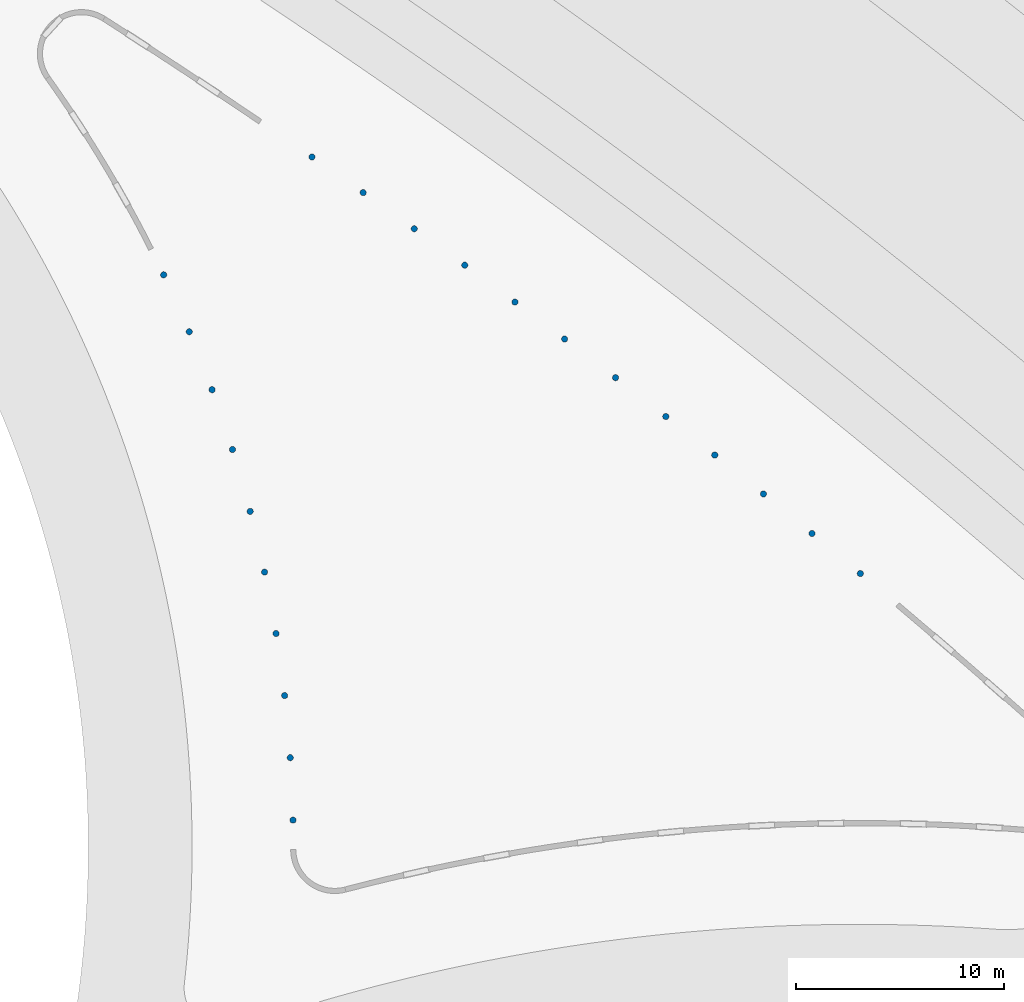
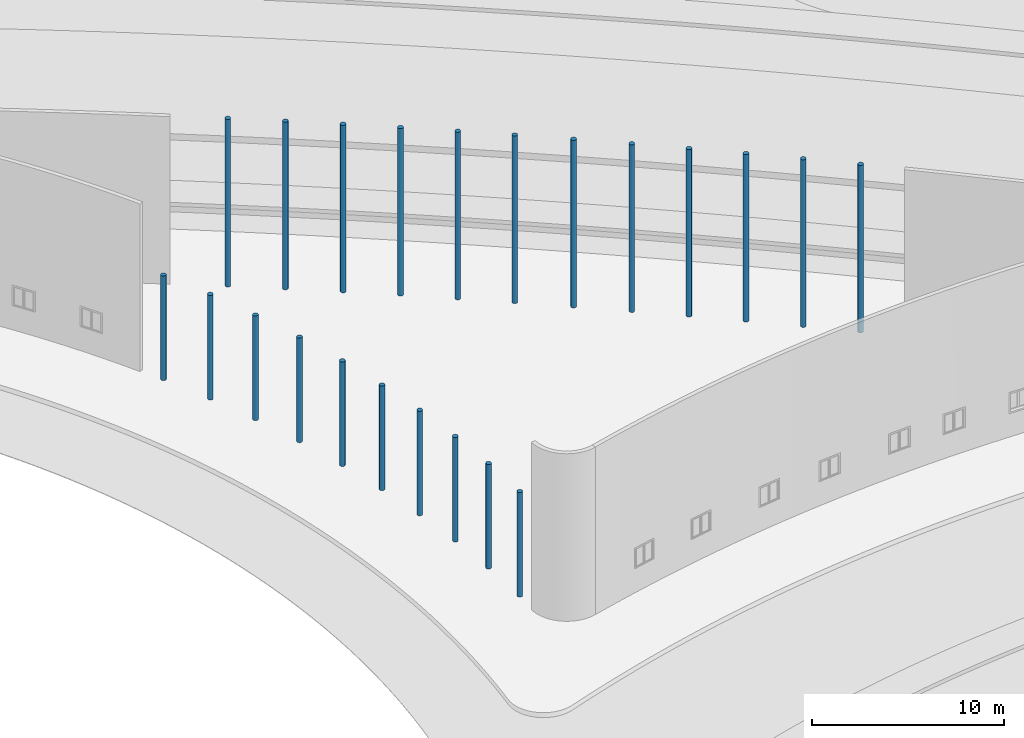
# One storey, part 5 of 39: 22 columns.
"""IFC2X3 building model written with IfcOpenShell, lengths in millimetres."""

from ifc_helpers import new_model, entity, si_unit, converted_unit, derived_unit, direction, frame, frame_2d, origin, place, context, subcontext, project, spatial, circle, extrude, source, transform, mapped, material, type_object, type_shapes, element, save


model = new_model("IFC2X3")

# Units and contexts
model_context = context("Model", 3, precision=1e-06, world=origin(), true_north=direction((2.0, 6.12303176911189e-17, 1.0)))
context_of_model = context(None, 3, precision=1e-06, world=origin(), true_north=direction((2.0, 6.12303176911189e-17, 1.0)))
body_context = subcontext(model_context, "Body", "Model", "MODEL_VIEW")
ifc_project = project(units=[si_unit("LENGTHUNIT", "METRE", prefix="MILLI"), si_unit("AREAUNIT", "SQUARE_METRE", prefix="MILLI"), si_unit("VOLUMEUNIT", "CUBIC_METRE", prefix="MILLI"), converted_unit("PLANEANGLEUNIT", "DEGREE", entity("IfcRatioMeasure", 0.0174532925199433), si_unit("PLANEANGLEUNIT", "RADIAN"), dimensions=[0, 0, 0, 0, 0, 0, 0]), si_unit("MASSUNIT", "GRAM", prefix="KILO"), si_unit("TIMEUNIT", "SECOND"), si_unit("THERMODYNAMICTEMPERATUREUNIT", "KELVIN"), derived_unit("THERMALTRANSMITTANCEUNIT", [(si_unit("MASSUNIT", "GRAM", prefix="KILO"), 1), (si_unit("THERMODYNAMICTEMPERATUREUNIT", "KELVIN"), -1), (si_unit("TIMEUNIT", "SECOND"), -3)]), derived_unit("VOLUMETRICFLOWRATEUNIT", [(si_unit("LENGTHUNIT", "METRE"), 3), (si_unit("TIMEUNIT", "SECOND"), -1)])], contexts=[model_context, context_of_model])

# Site, building, storey
site_placement = place(None, origin())
site = spatial("IfcSite", under=ifc_project, at=site_placement, CompositionType="ELEMENT")
building_placement = place(site_placement, origin())
building = spatial("IfcBuilding", under=site, at=building_placement, CompositionType="ELEMENT")
storey_placement = place(building_placement, frame((0.0, 0.0, 4000.0)))
storey = spatial("IfcBuildingStorey", under=building, at=storey_placement, Name="Level 2", CompositionType="ELEMENT", Elevation=4000.0)

# Columns
ifc_material = material(Name="Concrete - Cast-in-Place Concrete")
column_type_1 = type_object("IfcColumnType", Name="300mm", PredefinedType="COLUMN", material=ifc_material)
shared_shape_1 = source(origin(), body_context, "Body", "SweptSolid", [
    extrude(circle(Radius=149.999999999996, at=frame_2d((346754.447206508, 619569.745240384), x_axis=(1.0, 0.0))), origin(), (0.0, 0.0, 1.0), 10638.0),
])
type_shapes(column_type_1, [shared_shape_1])
column_1_placement = place(storey_placement, frame((0.0, 0.0, 362.0)))
element("IfcColumn", 1, at=column_1_placement, inside=storey, type_object=column_type_1, material=ifc_material, Name="M_Concrete-Round-Column:300mm", ObjectType="300mm", context=body_context, shape_type="MappedRepresentation", body=[
    mapped(shared_shape_1, transform((0.0, 0.0, 0.0), scale=1.0)),
])
column_type_2 = type_object("IfcColumnType", Name="300mm", PredefinedType="COLUMN", material=ifc_material)
shared_shape_2 = source(origin(), body_context, "Body", "SweptSolid", [
    extrude(circle(Radius=149.999999999996, at=frame_2d((349146.48282445, 617790.402335586), x_axis=(1.0, 0.0))), origin(), (0.0, 0.0, 1.0), 10638.0),
])
type_shapes(column_type_2, [shared_shape_2])
column_2_placement = place(storey_placement, frame((0.0, 0.0, 362.0)))
element("IfcColumn", 2, at=column_2_placement, inside=storey, type_object=column_type_2, material=ifc_material, Name="M_Concrete-Round-Column:300mm", ObjectType="300mm", context=body_context, shape_type="MappedRepresentation", body=[
    mapped(shared_shape_2, transform((0.0, 0.0, 0.0), scale=1.0)),
])
column_type_3 = type_object("IfcColumnType", Name="300mm", PredefinedType="COLUMN", material=ifc_material)
shared_shape_3 = source(origin(), body_context, "Body", "SweptSolid", [
    extrude(circle(Radius=149.999999999996, at=frame_2d((351599.443039313, 615927.860869081), x_axis=(1.0, 0.0))), origin(), (0.0, 0.0, 1.0), 10638.0),
])
type_shapes(column_type_3, [shared_shape_3])
column_3_placement = place(storey_placement, frame((0.0, 0.0, 362.0)))
element("IfcColumn", 3, at=column_3_placement, inside=storey, type_object=column_type_3, material=ifc_material, Name="M_Concrete-Round-Column:300mm", ObjectType="300mm", context=body_context, shape_type="MappedRepresentation", body=[
    mapped(shared_shape_3, transform((0.0, 0.0, 0.0), scale=1.0)),
])
column_type_4 = type_object("IfcColumnType", Name="300mm", PredefinedType="COLUMN", material=ifc_material)
shared_shape_4 = source(origin(), body_context, "Body", "SweptSolid", [
    extrude(circle(Radius=149.999999999996, at=frame_2d((354019.70140571, 614057.31510408), x_axis=(1.0, 0.0))), origin(), (0.0, 0.0, 1.0), 10638.0),
])
type_shapes(column_type_4, [shared_shape_4])
column_4_placement = place(storey_placement, frame((0.0, 0.0, 362.0)))
element("IfcColumn", 4, at=column_4_placement, inside=storey, type_object=column_type_4, material=ifc_material, Name="M_Concrete-Round-Column:300mm", ObjectType="300mm", context=body_context, shape_type="MappedRepresentation", body=[
    mapped(shared_shape_4, transform((0.0, 0.0, 0.0), scale=1.0)),
])
column_type_5 = type_object("IfcColumnType", Name="300mm", PredefinedType="COLUMN", material=ifc_material)
shared_shape_5 = source(origin(), body_context, "Body", "SweptSolid", [
    extrude(circle(Radius=149.999999999996, at=frame_2d((356378.626752312, 612202.162924711), x_axis=(1.0, 0.0))), origin(), (0.0, 0.0, 1.0), 10638.0),
])
type_shapes(column_type_5, [shared_shape_5])
column_5_placement = place(storey_placement, frame((0.0, 0.0, 362.0)))
element("IfcColumn", 5, at=column_5_placement, inside=storey, type_object=column_type_5, material=ifc_material, Name="M_Concrete-Round-Column:300mm", ObjectType="300mm", context=body_context, shape_type="MappedRepresentation", body=[
    mapped(shared_shape_5, transform((0.0, 0.0, 0.0), scale=1.0)),
])
column_type_6 = type_object("IfcColumnType", Name="300mm", PredefinedType="COLUMN", material=ifc_material)
shared_shape_6 = source(origin(), body_context, "Body", "SweptSolid", [
    extrude(circle(Radius=149.999999999996, at=frame_2d((358721.707253931, 610327.564317093), x_axis=(1.0, 0.0))), origin(), (0.0, 0.0, 1.0), 10638.0),
])
type_shapes(column_type_6, [shared_shape_6])
column_6_placement = place(storey_placement, frame((0.0, 0.0, 362.0)))
element("IfcColumn", 6, at=column_6_placement, inside=storey, type_object=column_type_6, material=ifc_material, Name="M_Concrete-Round-Column:300mm", ObjectType="300mm", context=body_context, shape_type="MappedRepresentation", body=[
    mapped(shared_shape_6, transform((0.0, 0.0, 0.0), scale=1.0)),
])
column_type_7 = type_object("IfcColumnType", Name="300mm", PredefinedType="COLUMN", material=ifc_material)
shared_shape_7 = source(origin(), body_context, "Body", "SweptSolid", [
    extrude(circle(Radius=149.999999999996, at=frame_2d((361061.59004054, 608423.144943194), x_axis=(1.0, 0.0))), origin(), (0.0, 0.0, 1.0), 10638.0),
])
type_shapes(column_type_7, [shared_shape_7])
column_7_placement = place(storey_placement, frame((0.0, 0.0, 362.0)))
element("IfcColumn", 7, at=column_7_placement, inside=storey, type_object=column_type_7, material=ifc_material, Name="M_Concrete-Round-Column:300mm", ObjectType="300mm", context=body_context, shape_type="MappedRepresentation", body=[
    mapped(shared_shape_7, transform((0.0, 0.0, 0.0), scale=1.0)),
])
column_type_8 = type_object("IfcColumnType", Name="300mm", PredefinedType="COLUMN", material=ifc_material)
shared_shape_8 = source(origin(), body_context, "Body", "SweptSolid", [
    extrude(circle(Radius=149.999999999996, at=frame_2d((363388.77577113, 606496.301061358), x_axis=(1.0, 0.0))), origin(), (0.0, 0.0, 1.0), 10638.0),
])
type_shapes(column_type_8, [shared_shape_8])
column_8_placement = place(storey_placement, frame((0.0, 0.0, 362.0)))
element("IfcColumn", 8, at=column_8_placement, inside=storey, type_object=column_type_8, material=ifc_material, Name="M_Concrete-Round-Column:300mm", ObjectType="300mm", context=body_context, shape_type="MappedRepresentation", body=[
    mapped(shared_shape_8, transform((0.0, 0.0, 0.0), scale=1.0)),
])
column_type_9 = type_object("IfcColumnType", Name="300mm", PredefinedType="COLUMN", material=ifc_material)
shared_shape_9 = source(origin(), body_context, "Body", "SweptSolid", [
    extrude(circle(Radius=149.999999999996, at=frame_2d((344337.193805384, 621347.331034732), x_axis=(1.0, 0.0))), origin(), (0.0, 0.0, 1.0), 10638.0),
])
type_shapes(column_type_9, [shared_shape_9])
column_9_placement = place(storey_placement, frame((0.0, 0.0, 362.0)))
element("IfcColumn", 9, at=column_9_placement, inside=storey, type_object=column_type_9, material=ifc_material, Name="M_Concrete-Round-Column:300mm", ObjectType="300mm", context=body_context, shape_type="MappedRepresentation", body=[
    mapped(shared_shape_9, transform((0.0, 0.0, 0.0), scale=1.0)),
])
column_type_10 = type_object("IfcColumnType", Name="300mm", PredefinedType="COLUMN", material=ifc_material)
shared_shape_10 = source(origin(), body_context, "Body", "SweptSolid", [
    extrude(circle(Radius=149.999999999996, at=frame_2d((341902.491759259, 623101.338115641), x_axis=(1.0, 0.0))), origin(), (0.0, 0.0, 1.0), 10638.0),
])
type_shapes(column_type_10, [shared_shape_10])
column_10_placement = place(storey_placement, frame((0.0, 0.0, 362.0)))
element("IfcColumn", 10, at=column_10_placement, inside=storey, type_object=column_type_10, material=ifc_material, Name="M_Concrete-Round-Column:300mm", ObjectType="300mm", context=body_context, shape_type="MappedRepresentation", body=[
    mapped(shared_shape_10, transform((0.0, 0.0, 0.0), scale=1.0)),
])
column_type_11 = type_object("IfcColumnType", Name="300mm", PredefinedType="COLUMN", material=ifc_material)
shared_shape_11 = source(origin(), body_context, "Body", "SweptSolid", [
    extrude(circle(Radius=149.999999999996, at=frame_2d((339442.240377003, 624842.633838839), x_axis=(1.0, 0.0))), origin(), (0.0, 0.0, 1.0), 10638.0),
])
type_shapes(column_type_11, [shared_shape_11])
column_11_placement = place(storey_placement, frame((0.0, 0.0, 362.0)))
element("IfcColumn", 11, at=column_11_placement, inside=storey, type_object=column_type_11, material=ifc_material, Name="M_Concrete-Round-Column:300mm", ObjectType="300mm", context=body_context, shape_type="MappedRepresentation", body=[
    mapped(shared_shape_11, transform((0.0, 0.0, 0.0), scale=1.0)),
])
column_type_12 = type_object("IfcColumnType", Name="300mm", PredefinedType="COLUMN", material=ifc_material)
shared_shape_12 = source(origin(), body_context, "Body", "SweptSolid", [
    extrude(circle(Radius=149.999999999996, at=frame_2d((336974.184427757, 626558.578376158), x_axis=(1.0, 0.0))), origin(), (0.0, 0.0, 1.0), 10638.0),
])
type_shapes(column_type_12, [shared_shape_12])
column_12_placement = place(storey_placement, frame((0.0, 0.0, 362.0)))
element("IfcColumn", 12, at=column_12_placement, inside=storey, type_object=column_type_12, material=ifc_material, Name="M_Concrete-Round-Column:300mm", ObjectType="300mm", context=body_context, shape_type="MappedRepresentation", body=[
    mapped(shared_shape_12, transform((0.0, 0.0, 0.0), scale=1.0)),
])
column_type_13 = type_object("IfcColumnType", Name="300mm", PredefinedType="COLUMN", material=ifc_material)
shared_shape_13 = source(origin(), body_context, "Body", "SweptSolid", [
    extrude(circle(Radius=149.999999999996, at=frame_2d((329834.366143612, 620882.843177091), x_axis=(1.0, 0.0))), origin(), (0.0, 0.0, 1.0), 6638.0),
])
type_shapes(column_type_13, [shared_shape_13])
column_13_placement = place(storey_placement, frame((0.0, 0.0, 362.0)))
element("IfcColumn", 13, at=column_13_placement, inside=storey, type_object=column_type_13, material=ifc_material, Name="M_Concrete-Round-Column:300mm", ObjectType="300mm", context=body_context, shape_type="MappedRepresentation", body=[
    mapped(shared_shape_13, transform((0.0, 0.0, 0.0), scale=1.0)),
])
column_type_14 = type_object("IfcColumnType", Name="300mm", PredefinedType="COLUMN", material=ifc_material)
shared_shape_14 = source(origin(), body_context, "Body", "SweptSolid", [
    extrude(circle(Radius=149.999999999996, at=frame_2d((331065.860679054, 618141.611257789), x_axis=(1.0, 0.0))), origin(), (0.0, 0.0, 1.0), 6638.0),
])
type_shapes(column_type_14, [shared_shape_14])
column_14_placement = place(storey_placement, frame((0.0, 0.0, 362.0)))
element("IfcColumn", 14, at=column_14_placement, inside=storey, type_object=column_type_14, material=ifc_material, Name="M_Concrete-Round-Column:300mm", ObjectType="300mm", context=body_context, shape_type="MappedRepresentation", body=[
    mapped(shared_shape_14, transform((0.0, 0.0, 0.0), scale=1.0)),
])
column_type_15 = type_object("IfcColumnType", Name="300mm", PredefinedType="COLUMN", material=ifc_material)
shared_shape_15 = source(origin(), body_context, "Body", "SweptSolid", [
    extrude(circle(Radius=149.999999999996, at=frame_2d((332165.909530705, 615348.626575068), x_axis=(1.0, 0.0))), origin(), (0.0, 0.0, 1.0), 6638.0),
])
type_shapes(column_type_15, [shared_shape_15])
column_15_placement = place(storey_placement, frame((0.0, 0.0, 362.0)))
element("IfcColumn", 15, at=column_15_placement, inside=storey, type_object=column_type_15, material=ifc_material, Name="M_Concrete-Round-Column:300mm", ObjectType="300mm", context=body_context, shape_type="MappedRepresentation", body=[
    mapped(shared_shape_15, transform((0.0, 0.0, 0.0), scale=1.0)),
])
column_type_16 = type_object("IfcColumnType", Name="300mm", PredefinedType="COLUMN", material=ifc_material)
shared_shape_16 = source(origin(), body_context, "Body", "SweptSolid", [
    extrude(circle(Radius=149.999999999996, at=frame_2d((333146.117953326, 612466.95060306), x_axis=(1.0, 0.0))), origin(), (0.0, 0.0, 1.0), 6638.0),
])
type_shapes(column_type_16, [shared_shape_16])
column_16_placement = place(storey_placement, frame((0.0, 0.0, 362.0)))
element("IfcColumn", 16, at=column_16_placement, inside=storey, type_object=column_type_16, material=ifc_material, Name="M_Concrete-Round-Column:300mm", ObjectType="300mm", context=body_context, shape_type="MappedRepresentation", body=[
    mapped(shared_shape_16, transform((0.0, 0.0, 0.0), scale=1.0)),
])
column_type_17 = type_object("IfcColumnType", Name="300mm", PredefinedType="COLUMN", material=ifc_material)
shared_shape_17 = source(origin(), body_context, "Body", "SweptSolid", [
    extrude(circle(Radius=149.999999999996, at=frame_2d((334001.836432385, 609488.720371843), x_axis=(1.0, 0.0))), origin(), (0.0, 0.0, 1.0), 6638.0),
])
type_shapes(column_type_17, [shared_shape_17])
column_17_placement = place(storey_placement, frame((0.0, 0.0, 362.0)))
element("IfcColumn", 17, at=column_17_placement, inside=storey, type_object=column_type_17, material=ifc_material, Name="M_Concrete-Round-Column:300mm", ObjectType="300mm", context=body_context, shape_type="MappedRepresentation", body=[
    mapped(shared_shape_17, transform((0.0, 0.0, 0.0), scale=1.0)),
])
column_type_18 = type_object("IfcColumnType", Name="300mm", PredefinedType="COLUMN", material=ifc_material)
shared_shape_18 = source(origin(), body_context, "Body", "SweptSolid", [
    extrude(circle(Radius=149.999999999996, at=frame_2d((334692.997826415, 606563.165945777), x_axis=(1.0, 0.0))), origin(), (0.0, 0.0, 1.0), 6638.0),
])
type_shapes(column_type_18, [shared_shape_18])
column_18_placement = place(storey_placement, frame((0.0, 0.0, 362.0)))
element("IfcColumn", 18, at=column_18_placement, inside=storey, type_object=column_type_18, material=ifc_material, Name="M_Concrete-Round-Column:300mm", ObjectType="300mm", context=body_context, shape_type="MappedRepresentation", body=[
    mapped(shared_shape_18, transform((0.0, 0.0, 0.0), scale=1.0)),
])
column_type_19 = type_object("IfcColumnType", Name="300mm", PredefinedType="COLUMN", material=ifc_material)
shared_shape_19 = source(origin(), body_context, "Body", "SweptSolid", [
    extrude(circle(Radius=149.999999999996, at=frame_2d((335246.515878679, 603603.623468021), x_axis=(1.0, 0.0))), origin(), (0.0, 0.0, 1.0), 6638.0),
])
type_shapes(column_type_19, [shared_shape_19])
column_19_placement = place(storey_placement, frame((0.0, 0.0, 362.0)))
element("IfcColumn", 19, at=column_19_placement, inside=storey, type_object=column_type_19, material=ifc_material, Name="M_Concrete-Round-Column:300mm", ObjectType="300mm", context=body_context, shape_type="MappedRepresentation", body=[
    mapped(shared_shape_19, transform((0.0, 0.0, 0.0), scale=1.0)),
])
column_type_20 = type_object("IfcColumnType", Name="300mm", PredefinedType="COLUMN", material=ifc_material)
shared_shape_20 = source(origin(), body_context, "Body", "SweptSolid", [
    extrude(circle(Radius=149.999999999996, at=frame_2d((335660.51472955, 600616.398833845), x_axis=(1.0, 0.0))), origin(), (0.0, 0.0, 1.0), 6638.0),
])
type_shapes(column_type_20, [shared_shape_20])
column_20_placement = place(storey_placement, frame((0.0, 0.0, 362.0)))
element("IfcColumn", 20, at=column_20_placement, inside=storey, type_object=column_type_20, material=ifc_material, Name="M_Concrete-Round-Column:300mm", ObjectType="300mm", context=body_context, shape_type="MappedRepresentation", body=[
    mapped(shared_shape_20, transform((0.0, 0.0, 0.0), scale=1.0)),
])
column_type_21 = type_object("IfcColumnType", Name="300mm", PredefinedType="COLUMN", material=ifc_material)
shared_shape_21 = source(origin(), body_context, "Body", "SweptSolid", [
    extrude(circle(Radius=149.999999999996, at=frame_2d((335932.213130899, 597625.489429685), x_axis=(1.0, 0.0))), origin(), (0.0, 0.0, 1.0), 6638.0),
])
type_shapes(column_type_21, [shared_shape_21])
column_21_placement = place(storey_placement, frame((0.0, 0.0, 362.0)))
element("IfcColumn", 21, at=column_21_placement, inside=storey, type_object=column_type_21, material=ifc_material, Name="M_Concrete-Round-Column:300mm", ObjectType="300mm", context=body_context, shape_type="MappedRepresentation", body=[
    mapped(shared_shape_21, transform((0.0, 0.0, 0.0), scale=1.0)),
])
column_type_22 = type_object("IfcColumnType", Name="300mm", PredefinedType="COLUMN", material=ifc_material)
shared_shape_22 = source(origin(), body_context, "Body", "SweptSolid", [
    extrude(circle(Radius=149.999999999996, at=frame_2d((336063.189949961, 594616.909290496), x_axis=(1.0, 0.0))), origin(), (0.0, 0.0, 1.0), 6638.0),
])
type_shapes(column_type_22, [shared_shape_22])
column_22_placement = place(storey_placement, frame((0.0, 0.0, 362.0)))
element("IfcColumn", 22, at=column_22_placement, inside=storey, type_object=column_type_22, material=ifc_material, Name="M_Concrete-Round-Column:300mm", ObjectType="300mm", context=body_context, shape_type="MappedRepresentation", body=[
    mapped(shared_shape_22, transform((0.0, 0.0, 0.0), scale=1.0)),
])

save(model, "model.ifc")
